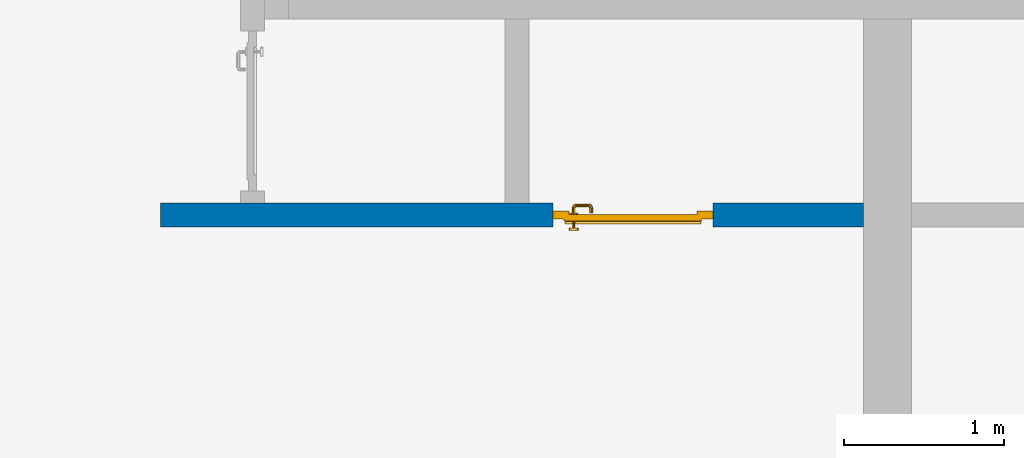
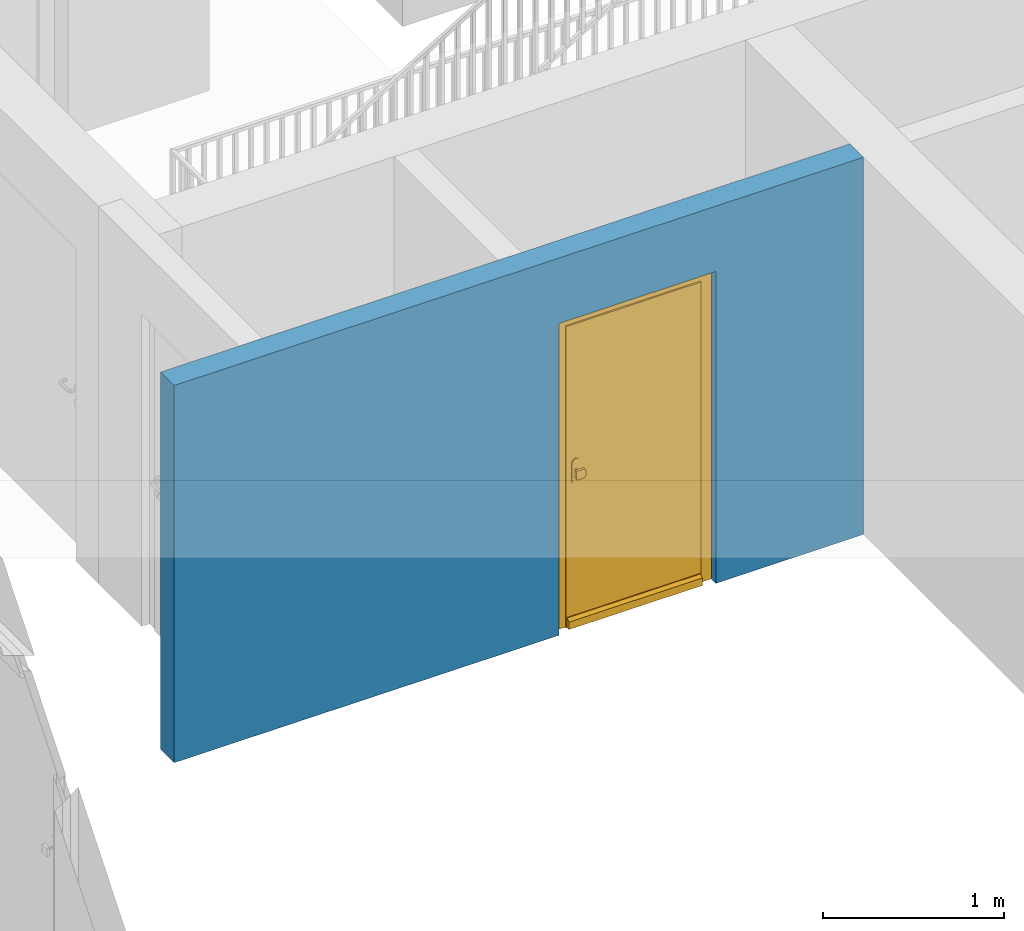
# One storey, part 2 of 54: 1 door, 1 wall, 1 opening.
"""IFC4 building model written with IfcOpenShell, lengths in metres."""

from ifc_helpers import new_model, entity, si_unit, converted_unit, derived_unit, direction, frame, origin_with_axes, place, context, subcontext, project, spatial, polygons, source, transform, mapped, material, type_object, element, fill, save


model = new_model("IFC4")

# Units and contexts
model_context = context("Model", 3, precision=1e-05, world=origin_with_axes(), true_north=direction((0.0, 1.0)))
body_context = subcontext(model_context, "Body", "Model", "MODEL_VIEW")
ifc_project = project(units=[si_unit("LENGTHUNIT", "METRE"), si_unit("AREAUNIT", "SQUARE_METRE"), si_unit("VOLUMEUNIT", "CUBIC_METRE"), converted_unit("PLANEANGLEUNIT", "DEGREE", entity("IfcPlaneAngleMeasure", 0.0174532925199), si_unit("PLANEANGLEUNIT", "RADIAN"), dimensions=[0, 0, 0, 0, 0, 0, 0]), converted_unit("TIMEUNIT", "Year", entity("IfcTimeMeasure", 31556926.0), si_unit("TIMEUNIT", "SECOND"), dimensions=[0, 0, 1, 0, 0, 0, 0]), si_unit("MASSUNIT", "GRAM", prefix="KILO"), si_unit("THERMODYNAMICTEMPERATUREUNIT", "DEGREE_CELSIUS"), si_unit("LUMINOUSINTENSITYUNIT", "LUMEN"), si_unit("ENERGYUNIT", "JOULE", prefix="MEGA"), derived_unit("THERMALCONDUCTANCEUNIT", [(si_unit("POWERUNIT", "WATT"), 1), (si_unit("LENGTHUNIT", "METRE"), -1), (si_unit("THERMODYNAMICTEMPERATUREUNIT", "KELVIN"), -1)]), derived_unit("SPECIFICHEATCAPACITYUNIT", [(si_unit("ENERGYUNIT", "JOULE"), 1), (si_unit("MASSUNIT", "GRAM", prefix="KILO"), -1), (si_unit("THERMODYNAMICTEMPERATUREUNIT", "KELVIN"), -1)]), derived_unit("MASSDENSITYUNIT", [(si_unit("MASSUNIT", "GRAM", prefix="KILO"), 1), (si_unit("VOLUMEUNIT", "CUBIC_METRE"), -1)])], contexts=[model_context])

# Site, building, storey
site_placement = place(None, origin_with_axes())
site = spatial("IfcSite", under=ifc_project, at=site_placement, CompositionType="ELEMENT")
building_placement = place(site_placement, origin_with_axes())
building = spatial("IfcBuilding", under=site, at=building_placement, CompositionType="ELEMENT")
storey_placement = place(building_placement, frame((0.0, 0.0, 6.29), z_axis=(0.0, 0.0, 1.0), x_axis=(1.0, 0.0, 0.0)))
storey = spatial("IfcBuildingStorey", under=building, at=storey_placement, Name="2. Geschoss", CompositionType="ELEMENT", Elevation=6.29)

# Wall, opening, door
ifc_material = material()
wall_type = type_object("IfcWallType", Name="150", PredefinedType="NOTDEFINED")
wall_placement = place(storey_placement, frame((-5.7421993804, -4.12881223104, 0.0), z_axis=(0.0, 0.0, 1.0), x_axis=(1.0, 0.0, 0.0)))
wall = element("IfcWall", 1, at=wall_placement, inside=storey, type_object=wall_type, material=ifc_material, Name="Wand-002", PredefinedType="NOTDEFINED", context=body_context, shape_type="Tessellation", body=[
    polygons([(2.45, 0.15, 2.1), (2.45, 0.15, 0.0), (0.0, 0.15, 0.0), (0.0, 0.15, 2.54), (4.39, 0.15, 2.54), (4.39, 0.15, 0.0), (3.45, 0.15, 0.0), (3.45, 0.15, 2.1), (2.45, 0.05, 0.0), (2.45, 0.0, 2.1), (2.45, 0.0, 0.0), (0.0, 0.0, 0.0), (0.0, 0.0, 2.54), (4.39, 0.0, 2.54), (4.39, 0.0, 0.0), (3.45, 0.05, 0.0), (3.45, 0.0, 0.0), (3.45, 0.0, 2.1)], [[[1, 2, 3, 4, 5, 6, 7, 8]], [[9, 2, 1, 10, 11]], [[2, 9, 11, 12, 3]], [[4, 3, 12, 13]], [[5, 4, 13, 14]], [[14, 15, 6, 5]], [[16, 7, 6, 15, 17]], [[8, 7, 16, 17, 18]], [[1, 8, 18, 10]], [[12, 11, 10, 18, 17, 15, 14, 13]]], closed=True),
])
opening_placement = place(wall_placement, frame((2.95, 0.0, 0.0), z_axis=(0.0, 0.0, 1.0), x_axis=(1.0, 0.0, 0.0)))
opening = element("IfcOpeningElement", 2, at=opening_placement, cuts=wall, context=body_context, identifier="Reference", shape_type="Tessellation", body=[
    polygons([(0.5, 0.05, 0.0), (0.5, 0.05, 2.1), (0.5, -0.001, 2.1), (0.5, -0.001, 0.0), (0.5, 0.151, 0.0), (0.5, 0.151, 2.1), (-0.5, 0.05, 2.1), (-0.5, -0.001, 2.1), (-0.5, 0.151, 2.1), (-0.5, -0.001, 0.0), (-0.5, 0.05, 0.0), (-0.5, 0.151, 0.0)], [[[1, 2, 3, 4]], [[2, 1, 5, 6]], [[7, 8, 3, 2, 6, 9]], [[8, 10, 4, 3]], [[1, 4, 10, 11, 12, 5]], [[6, 5, 12, 9]], [[7, 11, 10, 8]], [[11, 7, 9, 12]]], closed=True),
])
door_type = type_object("IfcDoorType", Name="Eingang 01 1-Fl 26", OperationType="SINGLE_SWING_LEFT", PredefinedType="DOOR")
shared_shape = source(origin_with_axes(), body_context, "Body", "Tessellation", [
    polygons([(-0.5, -0.05, 0.0), (-0.5, -0.05, 2.1), (-0.5, -0.03, 2.1), (-0.5, -0.03, 0.0), (-0.4, -0.05, 0.0), (-0.4, -0.05, 2.0), (-0.1301, -0.05, 2.0), (-0.0001, -0.05, 2.0), (0.4, -0.05, 2.0), (0.4, -0.05, 0.0), (0.5, -0.05, 0.0), (0.5, -0.05, 2.1), (0.5, -0.03, 2.1), (0.5, -0.03, 0.0), (0.4, -0.03, 0.0), (0.4, -0.03, 2.0), (-0.0001, -0.03, 2.0), (-0.1301, -0.03, 2.0), (-0.4, -0.03, 2.0), (-0.4, -0.03, 0.0)], [[[1, 2, 3, 4]], [[1, 5, 6, 7, 8, 9, 10, 11, 12, 2]], [[2, 12, 13, 3]], [[4, 3, 13, 14, 15, 16, 17, 18, 19, 20]], [[5, 1, 4, 20]], [[6, 5, 20, 19]], [[7, 6, 19, 18]], [[8, 7, 18, 17]], [[9, 8, 17, 16]], [[10, 9, 16, 15]], [[11, 10, 15, 14]], [[12, 11, 14, 13]]], closed=True),
    polygons([(-0.5, -0.03, 0.0), (-0.5, -0.03, 2.1), (-0.5, 0.0, 2.1), (-0.5, 0.0, 0.0), (-0.43, -0.03, 0.0), (-0.43, -0.03, 2.03), (-0.1001, -0.03, 2.03), (-0.0301, -0.03, 2.03), (0.43, -0.03, 2.03), (0.43, -0.03, 0.0), (0.5, -0.03, 0.0), (0.5, -0.03, 2.1), (0.5, 0.0, 2.1), (0.5, 0.0, 0.0), (0.43, 0.0, 0.0), (0.43, 0.0, 2.03), (-0.0301, 0.0, 2.03), (-0.1001, 0.0, 2.03), (-0.43, 0.0, 2.03), (-0.43, 0.0, 0.0)], [[[1, 2, 3, 4]], [[1, 5, 6, 7, 8, 9, 10, 11, 12, 2]], [[2, 12, 13, 3]], [[4, 3, 13, 14, 15, 16, 17, 18, 19, 20]], [[5, 1, 4, 20]], [[6, 5, 20, 19]], [[7, 6, 19, 18]], [[8, 7, 18, 17]], [[9, 8, 17, 16]], [[10, 9, 16, 15]], [[11, 10, 15, 14]], [[12, 11, 14, 13]]], closed=True),
    polygons([(-0.43, 0.01, 0.0), (-0.43, 0.01, 2.03), (0.43, 0.01, 2.03), (0.43, 0.01, 0.0), (-0.43, -0.03, 0.0), (-0.43, -0.03, 2.03), (0.43, -0.03, 2.03), (0.43, -0.03, 0.0)], [[[1, 2, 3, 4]], [[1, 5, 6, 2]], [[2, 6, 7, 3]], [[3, 7, 8, 4]], [[4, 8, 5, 1]], [[8, 7, 6, 5]]], closed=True),
    polygons([(-0.425, 0.03, 0.0), (-0.425, 0.03, 0.05), (0.425, 0.03, 0.05), (0.425, 0.03, 0.0), (-0.425, 0.01, 0.0), (-0.425, 0.01, 0.07), (-0.425, 0.015, 0.07), (0.425, 0.015, 0.07), (0.425, 0.01, 0.07), (0.425, 0.01, 0.0)], [[[1, 2, 3, 4]], [[1, 5, 6, 7, 2]], [[2, 7, 8, 3]], [[4, 3, 8, 9, 10]], [[5, 1, 4, 10]], [[6, 5, 10, 9]], [[7, 6, 9, 8]]], closed=True),
    polygons([(0.3835, -0.04, 1.0733826859), (0.3835, -0.0399, 1.0733826859), (0.37, -0.0399, 1.077), (0.37, -0.04, 1.077), (0.393382685902, -0.04, 1.0635), (0.393382685902, -0.0399, 1.0635), (0.3835, -0.0301, 1.0733826859), (0.37, -0.0301, 1.077), (0.3565, -0.0399, 1.0733826859), (0.3565, -0.04, 1.0733826859), (0.346617314098, -0.04, 1.0635), (0.343, -0.04, 1.05), (0.346617314098, -0.04, 1.0365), (0.3565, -0.04, 1.0266173141), (0.37, -0.04, 1.023), (0.3835, -0.04, 1.0266173141), (0.393382685902, -0.04, 1.0365), (0.397, -0.04, 1.05), (0.397, -0.0399, 1.05), (0.393382685902, -0.0301, 1.0635), (0.3835, -0.03, 1.0733826859), (0.37, -0.03, 1.077), (0.3565, -0.0301, 1.0733826859), (0.346617314098, -0.0399, 1.0635), (0.343, -0.0399, 1.05), (0.346617314098, -0.0399, 1.0365), (0.3565, -0.0399, 1.0266173141), (0.37, -0.0399, 1.023), (0.3835, -0.0399, 1.0266173141), (0.393382685902, -0.0399, 1.0365), (0.397, -0.0301, 1.05), (0.393382685902, -0.03, 1.0635), (0.397, -0.03, 1.05), (0.393382685902, -0.03, 1.0365), (0.3835, -0.03, 1.0266173141), (0.37, -0.03, 1.023), (0.3565, -0.03, 1.0266173141), (0.346617314098, -0.03, 1.0365), (0.343, -0.03, 1.05), (0.346617314098, -0.03, 1.0635), (0.3565, -0.03, 1.0733826859), (0.346617314098, -0.0301, 1.0635), (0.343, -0.0301, 1.05), (0.346617314098, -0.0301, 1.0365), (0.3565, -0.0301, 1.0266173141), (0.37, -0.0301, 1.023), (0.3835, -0.0301, 1.0266173141), (0.393382685902, -0.0301, 1.0365)], [[[1, 2, 3, 4]], [[5, 6, 2, 1]], [[2, 7, 8, 3]], [[4, 3, 9, 10]], [[4, 10, 11, 12, 13, 14, 15, 16, 17, 18, 5, 1]], [[18, 19, 6, 5]], [[6, 20, 7, 2]], [[7, 21, 22, 8]], [[3, 8, 23, 9]], [[10, 9, 24, 11]], [[11, 24, 25, 12]], [[12, 25, 26, 13]], [[13, 26, 27, 14]], [[14, 27, 28, 15]], [[15, 28, 29, 16]], [[16, 29, 30, 17]], [[17, 30, 19, 18]], [[19, 31, 20, 6]], [[20, 32, 21, 7]], [[22, 21, 32, 33, 34, 35, 36, 37, 38, 39, 40, 41]], [[8, 22, 41, 23]], [[9, 23, 42, 24]], [[24, 42, 43, 25]], [[25, 43, 44, 26]], [[26, 44, 45, 27]], [[27, 45, 46, 28]], [[28, 46, 47, 29]], [[29, 47, 48, 30]], [[30, 48, 31, 19]], [[31, 33, 32, 20]], [[48, 34, 33, 31]], [[47, 35, 34, 48]], [[46, 36, 35, 47]], [[45, 37, 36, 46]], [[44, 38, 37, 45]], [[43, 39, 38, 44]], [[42, 40, 39, 43]], [[23, 41, 40, 42]]], closed=True),
    polygons([(0.362532169224, -0.04, 0.959692280177), (0.363279754556, -0.04, 0.961639806549), (0.35655, -0.04, 0.973296083362), (0.346703916638, -0.04, 0.96345), (0.365, -0.04, 0.952886751346), (0.365, -0.04, 0.9544), (0.362532169224, -0.039, 0.959692280177), (0.363279754556, -0.039, 0.961639806549), (0.364624817685, -0.039, 0.965143815798), (0.364624817685, -0.04, 0.965143815798), (0.37, -0.04, 0.967425445323), (0.37, -0.04, 0.9769), (0.346617314098, -0.04, 0.9635), (0.3565, -0.04, 0.973382685902), (0.365, -0.04, 0.95), (0.3431, -0.04, 0.95), (0.365, -0.04, 0.947113248654), (0.365, -0.04, 0.941339745962), (0.365, -0.04, 0.9375), (0.365, -0.039, 0.9375), (0.365, -0.039, 0.941339745962), (0.365, -0.039, 0.947113248654), (0.365, -0.039, 0.95), (0.365, -0.039, 0.952886751346), (0.365, -0.039, 0.9544), (0.347569942042, -0.039, 0.96295), (0.35705, -0.039, 0.972430057958), (0.37, -0.039, 0.9759), (0.37, -0.039, 0.967425445323), (0.375375182315, -0.04, 0.965143815798), (0.376720245444, -0.04, 0.961639806549), (0.38345, -0.04, 0.973296083362), (0.37, -0.04, 0.977), (0.343, -0.04, 0.95), (0.346617314098, -0.0399, 0.9635), (0.3565, -0.0399, 0.973382685902), (0.346703916638, -0.04, 0.93655), (0.35655, -0.04, 0.926703916638), (0.37, -0.04, 0.9231), (0.37, -0.04, 0.9325), (0.366464466094, -0.04, 0.933964466094), (0.366464466094, -0.039, 0.933964466094), (0.37, -0.039, 0.9241), (0.35705, -0.039, 0.927569942042), (0.37, -0.039, 0.9325), (0.347569942042, -0.039, 0.93705), (0.3441, -0.039, 0.95), (0.347483339502, -0.039, 0.963), (0.357, -0.039, 0.972516660498), (0.37, -0.039, 0.976), (0.375375182315, -0.039, 0.965143815798), (0.38295, -0.039, 0.972430057958), (0.376720245444, -0.039, 0.961639806549), (0.377467830776, -0.039, 0.959692280177), (0.377467830776, -0.04, 0.959692280177), (0.375, -0.04, 0.9544), (0.375, -0.04, 0.952886751346), (0.393296083362, -0.04, 0.96345), (0.3835, -0.04, 0.973382685902), (0.37, -0.0399, 0.977), (0.346617314098, -0.04, 0.9365), (0.343, -0.0399, 0.95), (0.346617314098, -0.0301, 0.9635), (0.3565, -0.0301, 0.973382685902), (0.3565, -0.04, 0.926617314098), (0.37, -0.04, 0.923), (0.38345, -0.04, 0.926703916638), (0.375, -0.04, 0.941339745962), (0.375, -0.04, 0.9375), (0.373535533906, -0.04, 0.933964466094), (0.37, -0.039, 0.924), (0.357, -0.039, 0.927483339502), (0.38295, -0.039, 0.927569942042), (0.373535533906, -0.039, 0.933964466094), (0.375, -0.039, 0.9375), (0.375, -0.039, 0.941339745962), (0.347483339502, -0.039, 0.937), (0.344, -0.039, 0.95), (0.347483339502, -0.0389, 0.963), (0.357, -0.0389, 0.972516660498), (0.37, -0.0389, 0.976), (0.383, -0.039, 0.972516660498), (0.392430057958, -0.039, 0.96295), (0.375, -0.039, 0.952886751346), (0.375, -0.039, 0.9544), (0.375, -0.039, 0.95), (0.375, -0.039, 0.947113248654), (0.375, -0.04, 0.947113248654), (0.375, -0.04, 0.95), (0.3969, -0.04, 0.95), (0.393382685902, -0.04, 0.9635), (0.3835, -0.0399, 0.973382685902), (0.37, -0.0301, 0.977), (0.346617314098, -0.0399, 0.9365), (0.343, -0.0301, 0.95), (0.346617314098, -0.03, 0.9635), (0.3565, -0.03, 0.973382685902), (0.3565, -0.0399, 0.926617314098), (0.3835, -0.04, 0.926617314098), (0.37, -0.0399, 0.923), (0.393296083362, -0.04, 0.93655), (0.383, -0.039, 0.927483339502), (0.37, -0.0389, 0.924), (0.357, -0.0389, 0.927483339502), (0.392430057958, -0.039, 0.93705), (0.347483339502, -0.0389, 0.937), (0.344, -0.0389, 0.95), (0.347483339502, -0.0301, 0.963), (0.357, -0.0301, 0.972516660498), (0.37, -0.0301, 0.976), (0.383, -0.0389, 0.972516660498), (0.392516660498, -0.039, 0.963), (0.3959, -0.039, 0.95), (0.397, -0.04, 0.95), (0.393382685902, -0.0399, 0.9635), (0.3835, -0.0301, 0.973382685902), (0.37, -0.03, 0.977), (0.346617314098, -0.0301, 0.9365), (0.343, -0.03, 0.95), (0.346703916638, -0.03, 0.96345), (0.35655, -0.03, 0.973296083362), (0.3565, -0.0301, 0.926617314098), (0.393382685902, -0.04, 0.9365), (0.3835, -0.0399, 0.926617314098), (0.37, -0.0301, 0.923), (0.392516660498, -0.039, 0.937), (0.383, -0.0389, 0.927483339502), (0.37, -0.0301, 0.924), (0.357, -0.0301, 0.927483339502), (0.347483339502, -0.0301, 0.937), (0.344, -0.0301, 0.95), (0.347483339502, -0.03, 0.963), (0.357, -0.03, 0.972516660498), (0.37, -0.03, 0.976), (0.383, -0.0301, 0.972516660498), (0.392516660498, -0.0389, 0.963), (0.396, -0.039, 0.95), (0.397, -0.0399, 0.95), (0.393382685902, -0.0301, 0.9635), (0.3835, -0.03, 0.973382685902), (0.37, -0.03, 0.9769), (0.346617314098, -0.03, 0.9365), (0.3431, -0.03, 0.95), (0.347396736961, -0.03, 0.96305), (0.35695, -0.03, 0.972603263039), (0.3565, -0.03, 0.926617314098), (0.393382685902, -0.0399, 0.9365), (0.3835, -0.0301, 0.926617314098), (0.37, -0.03, 0.923), (0.392516660498, -0.0389, 0.937), (0.383, -0.0301, 0.927483339502), (0.37, -0.03, 0.924), (0.357, -0.03, 0.927483339502), (0.347483339502, -0.03, 0.937), (0.344, -0.03, 0.95), (0.37, -0.03, 0.9761), (0.383, -0.03, 0.972516660498), (0.392516660498, -0.0301, 0.963), (0.396, -0.0389, 0.95), (0.397, -0.0301, 0.95), (0.393382685902, -0.03, 0.9635), (0.38345, -0.03, 0.973296083362), (0.346703916638, -0.03, 0.93655), (0.3439, -0.03, 0.95), (0.35655, -0.03, 0.926703916638), (0.393382685902, -0.0301, 0.9365), (0.3835, -0.03, 0.926617314098), (0.37, -0.03, 0.9231), (0.392516660498, -0.0301, 0.937), (0.383, -0.03, 0.927483339502), (0.37, -0.03, 0.9239), (0.35695, -0.03, 0.927396736961), (0.347396736961, -0.03, 0.93695), (0.38305, -0.03, 0.972603263039), (0.392516660498, -0.03, 0.963), (0.396, -0.0301, 0.95), (0.397, -0.03, 0.95), (0.393296083362, -0.03, 0.96345), (0.393382685902, -0.03, 0.9365), (0.38345, -0.03, 0.926703916638), (0.392516660498, -0.03, 0.937), (0.38305, -0.03, 0.927396736961), (0.392603263039, -0.03, 0.96305), (0.396, -0.03, 0.95), (0.3969, -0.03, 0.95), (0.393296083362, -0.03, 0.93655), (0.392603263039, -0.03, 0.93695), (0.3961, -0.03, 0.95)], [[[1, 2, 3, 4, 5, 6]], [[1, 7, 8, 9, 10, 2]], [[10, 11, 12, 3, 2]], [[13, 4, 3, 14]], [[15, 5, 4, 16]], [[6, 5, 15, 17, 18, 19, 20, 21, 22, 23, 24, 25]], [[6, 25, 7, 1]], [[7, 25, 24, 26, 27, 8]], [[9, 8, 27, 28, 29]], [[10, 9, 29, 11]], [[30, 31, 32, 12, 11]], [[14, 3, 12, 33]], [[34, 16, 4, 13]], [[35, 13, 14, 36]], [[17, 15, 16, 37]], [[18, 17, 37, 38]], [[38, 39, 40, 41, 19, 18]], [[19, 41, 42, 20]], [[43, 44, 21, 20, 42, 45]], [[22, 21, 44, 46]], [[23, 22, 46, 47]], [[24, 23, 47, 26]], [[26, 48, 49, 27]], [[27, 49, 50, 28]], [[51, 29, 28, 52, 53]], [[11, 29, 51, 30]], [[30, 51, 53, 54, 55, 31]], [[55, 56, 57, 58, 32, 31]], [[33, 12, 32, 59]], [[36, 14, 33, 60]], [[61, 37, 16, 34]], [[62, 34, 13, 35]], [[63, 35, 36, 64]], [[65, 38, 37, 61]], [[66, 39, 38, 65]], [[39, 67, 68, 69, 70, 40]], [[41, 40, 45, 42]], [[43, 71, 72, 44]], [[73, 43, 45, 74, 75, 76]], [[44, 72, 77, 46]], [[46, 77, 78, 47]], [[47, 78, 48, 26]], [[48, 79, 80, 49]], [[49, 80, 81, 50]], [[28, 50, 82, 52]], [[54, 53, 52, 83, 84, 85]], [[55, 54, 85, 56]], [[85, 84, 86, 87, 76, 75, 69, 68, 88, 89, 57, 56]], [[57, 89, 90, 58]], [[59, 32, 58, 91]], [[60, 33, 59, 92]], [[64, 36, 60, 93]], [[94, 61, 34, 62]], [[95, 62, 35, 63]], [[96, 63, 64, 97]], [[98, 65, 61, 94]], [[99, 67, 39, 66]], [[100, 66, 65, 98]], [[88, 68, 67, 101]], [[70, 69, 75, 74]], [[40, 70, 74, 45]], [[73, 102, 71, 43]], [[71, 103, 104, 72]], [[76, 87, 105, 73]], [[72, 104, 106, 77]], [[77, 106, 107, 78]], [[78, 107, 79, 48]], [[79, 108, 109, 80]], [[80, 109, 110, 81]], [[50, 81, 111, 82]], [[52, 82, 112, 83]], [[86, 84, 83, 113]], [[87, 86, 113, 105]], [[89, 88, 101, 90]], [[91, 58, 90, 114]], [[92, 59, 91, 115]], [[93, 60, 92, 116]], [[97, 64, 93, 117]], [[118, 94, 62, 95]], [[119, 95, 63, 96]], [[120, 96, 97, 121]], [[122, 98, 94, 118]], [[123, 101, 67, 99]], [[124, 99, 66, 100]], [[125, 100, 98, 122]], [[105, 126, 102, 73]], [[102, 127, 103, 71]], [[103, 128, 129, 104]], [[104, 129, 130, 106]], [[106, 130, 131, 107]], [[107, 131, 108, 79]], [[108, 132, 133, 109]], [[109, 133, 134, 110]], [[81, 110, 135, 111]], [[82, 111, 136, 112]], [[83, 112, 137, 113]], [[113, 137, 126, 105]], [[114, 90, 101, 123]], [[115, 91, 114, 138]], [[116, 92, 115, 139]], [[117, 93, 116, 140]], [[121, 97, 117, 141]], [[142, 118, 95, 119]], [[143, 119, 96, 120]], [[144, 120, 121, 145]], [[146, 122, 118, 142]], [[147, 123, 99, 124]], [[148, 124, 100, 125]], [[149, 125, 122, 146]], [[126, 150, 127, 102]], [[127, 151, 128, 103]], [[128, 152, 153, 129]], [[129, 153, 154, 130]], [[130, 154, 155, 131]], [[131, 155, 132, 108]], [[132, 144, 145, 133]], [[133, 145, 156, 134]], [[110, 134, 157, 135]], [[111, 135, 158, 136]], [[112, 136, 159, 137]], [[137, 159, 150, 126]], [[138, 114, 123, 147]], [[139, 115, 138, 160]], [[140, 116, 139, 161]], [[141, 117, 140, 162]], [[145, 121, 141, 156]], [[163, 142, 119, 143]], [[164, 143, 120, 144]], [[165, 146, 142, 163]], [[166, 147, 124, 148]], [[167, 148, 125, 149]], [[168, 149, 146, 165]], [[150, 169, 151, 127]], [[151, 170, 152, 128]], [[152, 171, 172, 153]], [[153, 172, 173, 154]], [[154, 173, 164, 155]], [[155, 164, 144, 132]], [[134, 156, 174, 157]], [[135, 157, 175, 158]], [[136, 158, 176, 159]], [[159, 176, 169, 150]], [[160, 138, 147, 166]], [[161, 139, 160, 177]], [[162, 140, 161, 178]], [[156, 141, 162, 174]], [[173, 163, 143, 164]], [[172, 165, 163, 173]], [[179, 166, 148, 167]], [[180, 167, 149, 168]], [[171, 168, 165, 172]], [[169, 181, 170, 151]], [[170, 182, 171, 152]], [[157, 174, 183, 175]], [[158, 175, 184, 176]], [[176, 184, 181, 169]], [[177, 160, 166, 179]], [[178, 161, 177, 185]], [[174, 162, 178, 183]], [[186, 179, 167, 180]], [[182, 180, 168, 171]], [[181, 187, 182, 170]], [[175, 183, 188, 184]], [[184, 188, 187, 181]], [[185, 177, 179, 186]], [[183, 178, 185, 188]], [[187, 186, 180, 182]], [[188, 185, 186, 187]]], closed=True),
    polygons([(0.38, -0.04, 1.05), (0.38, -0.0709849140336, 1.05), (0.377071067812, -0.070696439392, 1.04292893219), (0.377071067812, -0.04, 1.04292893219), (0.377071067812, -0.04, 1.05707106781), (0.377071067812, -0.070696439392, 1.05707106781), (0.378277987014, -0.0796420579258, 1.05), (0.375518993221, -0.0784992452783, 1.04292893219), (0.37, -0.07, 1.04), (0.37, -0.04, 1.04), (0.37, -0.04, 1.06), (0.37, -0.07, 1.06), (0.375518993221, -0.0784992452783, 1.05707106781), (0.372816199938, -0.0878161999379, 1.05), (0.370704557509, -0.0857045575088, 1.04292893219), (0.368858192988, -0.0757402514855, 1.04), (0.362928932188, -0.069303560608, 1.04292893219), (0.362928932188, -0.04, 1.04292893219), (0.362928932188, -0.04, 1.05707106781), (0.362928932188, -0.069303560608, 1.05707106781), (0.368858192988, -0.0757402514855, 1.06), (0.370704557509, -0.0857045575088, 1.05707106781), (0.364642057926, -0.0932779870137, 1.05), (0.363499245278, -0.0905189932208, 1.04292893219), (0.365606601718, -0.0806066017178, 1.04), (0.362197392755, -0.0729812576926, 1.04292893219), (0.36, -0.0690150859664, 1.05), (0.36, -0.04, 1.05), (0.362197392755, -0.0729812576926, 1.05707106781), (0.365606601718, -0.0806066017178, 1.06), (0.363499245278, -0.0905189932208, 1.05707106781), (0.355984914034, -0.095, 1.05), (0.355696439392, -0.0920710678119, 1.04292893219), (0.360740251485, -0.0838581929877, 1.04), (0.360508645927, -0.0755086459268, 1.04292893219), (0.359438398962, -0.0718384450452, 1.05), (0.360508645927, -0.0755086459268, 1.05707106781), (0.360740251485, -0.0838581929877, 1.06), (0.355696439392, -0.0920710678119, 1.05707106781), (0.274015085966, -0.095, 1.05), (0.274303560608, -0.0920710678119, 1.04292893219), (0.355, -0.085, 1.04), (0.357981257693, -0.0771973927545, 1.04292893219), (0.358397003498, -0.0733970034977, 1.05), (0.357981257693, -0.0771973927545, 1.05707106781), (0.355, -0.085, 1.06), (0.274303560608, -0.0920710678119, 1.05707106781), (0.265357942074, -0.0932779870137, 1.05), (0.266500754722, -0.0905189932208, 1.04292893219), (0.275, -0.085, 1.04), (0.354303560608, -0.0779289321881, 1.04292893219), (0.356838445045, -0.0744383989617, 1.05), (0.354303560608, -0.0779289321881, 1.05707106781), (0.275, -0.085, 1.06), (0.266500754722, -0.0905189932208, 1.05707106781), (0.257183800062, -0.0878161999379, 1.05), (0.259295442491, -0.0857045575088, 1.04292893219), (0.269259748515, -0.0838581929877, 1.04), (0.275696439392, -0.0779289321881, 1.04292893219), (0.354015085966, -0.075, 1.05), (0.275696439392, -0.0779289321881, 1.05707106781), (0.269259748515, -0.0838581929877, 1.06), (0.259295442491, -0.0857045575088, 1.05707106781), (0.251722012986, -0.0796420579258, 1.05), (0.254481006779, -0.0784992452783, 1.04292893219), (0.264393398282, -0.0806066017178, 1.04), (0.272018742307, -0.0771973927545, 1.04292893219), (0.275984914034, -0.075, 1.05), (0.272018742307, -0.0771973927545, 1.05707106781), (0.264393398282, -0.0806066017178, 1.06), (0.254481006779, -0.0784992452783, 1.05707106781), (0.25, -0.0709849140336, 1.05), (0.252928932188, -0.070696439392, 1.04292893219), (0.261141807012, -0.0757402514855, 1.04), (0.269491354073, -0.0755086459268, 1.04292893219), (0.273161554955, -0.0744383989617, 1.05), (0.269491354073, -0.0755086459268, 1.05707106781), (0.261141807012, -0.0757402514855, 1.06), (0.252928932188, -0.070696439392, 1.05707106781), (0.25, -0.04, 1.05), (0.252928932188, -0.04, 1.04292893219), (0.26, -0.07, 1.04), (0.267802607245, -0.0729812576926, 1.04292893219), (0.271602996502, -0.0733970034977, 1.05), (0.267802607245, -0.0729812576926, 1.05707106781), (0.26, -0.07, 1.06), (0.252928932188, -0.04, 1.05707106781), (0.26, -0.04, 1.06), (0.267071067812, -0.04, 1.05707106781), (0.27, -0.04, 1.05), (0.267071067812, -0.04, 1.04292893219), (0.26, -0.04, 1.04), (0.267071067812, -0.069303560608, 1.04292893219), (0.270561601038, -0.0718384450452, 1.05), (0.267071067812, -0.069303560608, 1.05707106781), (0.27, -0.0690150859664, 1.05)], [[[1, 2, 3, 4]], [[5, 6, 2, 1]], [[2, 7, 8, 3]], [[4, 3, 9, 10]], [[11, 12, 6, 5]], [[6, 13, 7, 2]], [[7, 14, 15, 8]], [[3, 8, 16, 9]], [[10, 9, 17, 18]], [[19, 20, 12, 11]], [[12, 21, 13, 6]], [[13, 22, 14, 7]], [[14, 23, 24, 15]], [[8, 15, 25, 16]], [[9, 16, 26, 17]], [[18, 17, 27, 28]], [[28, 27, 20, 19]], [[20, 29, 21, 12]], [[21, 30, 22, 13]], [[22, 31, 23, 14]], [[23, 32, 33, 24]], [[15, 24, 34, 25]], [[16, 25, 35, 26]], [[17, 26, 36, 27]], [[27, 36, 29, 20]], [[29, 37, 30, 21]], [[30, 38, 31, 22]], [[31, 39, 32, 23]], [[32, 40, 41, 33]], [[24, 33, 42, 34]], [[25, 34, 43, 35]], [[26, 35, 44, 36]], [[36, 44, 37, 29]], [[37, 45, 38, 30]], [[38, 46, 39, 31]], [[39, 47, 40, 32]], [[40, 48, 49, 41]], [[33, 41, 50, 42]], [[34, 42, 51, 43]], [[35, 43, 52, 44]], [[44, 52, 45, 37]], [[45, 53, 46, 38]], [[46, 54, 47, 39]], [[47, 55, 48, 40]], [[48, 56, 57, 49]], [[41, 49, 58, 50]], [[42, 50, 59, 51]], [[43, 51, 60, 52]], [[52, 60, 53, 45]], [[53, 61, 54, 46]], [[54, 62, 55, 47]], [[55, 63, 56, 48]], [[56, 64, 65, 57]], [[49, 57, 66, 58]], [[50, 58, 67, 59]], [[51, 59, 68, 60]], [[60, 68, 61, 53]], [[61, 69, 62, 54]], [[62, 70, 63, 55]], [[63, 71, 64, 56]], [[64, 72, 73, 65]], [[57, 65, 74, 66]], [[58, 66, 75, 67]], [[59, 67, 76, 68]], [[68, 76, 69, 61]], [[69, 77, 70, 62]], [[70, 78, 71, 63]], [[71, 79, 72, 64]], [[72, 80, 81, 73]], [[65, 73, 82, 74]], [[66, 74, 83, 75]], [[67, 75, 84, 76]], [[76, 84, 77, 69]], [[77, 85, 78, 70]], [[78, 86, 79, 71]], [[79, 87, 80, 72]], [[80, 87, 88, 89, 90, 91, 92, 81]], [[73, 81, 92, 82]], [[74, 82, 93, 83]], [[75, 83, 94, 84]], [[84, 94, 85, 77]], [[85, 95, 86, 78]], [[86, 88, 87, 79]], [[95, 89, 88, 86]], [[96, 90, 89, 95]], [[93, 91, 90, 96]], [[82, 92, 91, 93]], [[83, 93, 96, 94]], [[94, 96, 95, 85]]], closed=False),
    polygons([(0.364696699141, 0.015, 1.04469669914), (0.37, 0.015, 1.0425), (0.375303300859, 0.015, 1.04469669914), (0.3775, 0.015, 1.05), (0.375303300859, 0.015, 1.05530330086), (0.37, 0.015, 1.0575), (0.364696699141, 0.015, 1.05530330086), (0.3625, 0.015, 1.05), (0.364696699141, 0.055, 1.04469669914), (0.37, 0.055, 1.0425), (0.375303300859, 0.055, 1.04469669914), (0.3775, 0.055, 1.05), (0.375303300859, 0.055, 1.05530330086), (0.37, 0.055, 1.0575), (0.364696699141, 0.055, 1.05530330086), (0.3625, 0.055, 1.05)], [[[1, 2, 3, 4, 5, 6, 7, 8]], [[2, 1, 9, 10]], [[3, 2, 10, 11]], [[4, 3, 11, 12]], [[5, 4, 12, 13]], [[6, 5, 13, 14]], [[7, 6, 14, 15]], [[8, 7, 15, 16]], [[1, 8, 16, 9]], [[9, 16, 15, 14, 13, 12, 11, 10]]], closed=True),
    polygons([(0.395, 0.01, 0.975), (0.393096988313, 0.01, 0.965432914191), (0.393096988313, 0.015, 0.965432914191), (0.395, 0.015, 0.975), (0.395, 0.01, 1.1), (0.393096988313, 0.01, 1.10956708581), (0.38767766953, 0.01, 1.11767766953), (0.379567085809, 0.01, 1.12309698831), (0.37, 0.01, 1.125), (0.360432914191, 0.01, 1.12309698831), (0.35232233047, 0.01, 1.11767766953), (0.346903011687, 0.01, 1.10956708581), (0.345, 0.01, 1.1), (0.345, 0.01, 0.975), (0.346903011687, 0.01, 0.965432914191), (0.35232233047, 0.01, 0.95732233047), (0.360432914191, 0.01, 0.951903011687), (0.37, 0.01, 0.95), (0.379567085809, 0.01, 0.951903011687), (0.38767766953, 0.01, 0.95732233047), (0.38767766953, 0.015, 0.95732233047), (0.379567085809, 0.015, 0.951903011687), (0.37, 0.015, 0.95), (0.360432914191, 0.015, 0.951903011687), (0.35232233047, 0.015, 0.95732233047), (0.346903011687, 0.015, 0.965432914191), (0.345, 0.015, 0.975), (0.345, 0.015, 1.1), (0.346903011687, 0.015, 1.10956708581), (0.35232233047, 0.015, 1.11767766953), (0.360432914191, 0.015, 1.12309698831), (0.37, 0.015, 1.125), (0.379567085809, 0.015, 1.12309698831), (0.38767766953, 0.015, 1.11767766953), (0.393096988313, 0.015, 1.10956708581), (0.395, 0.015, 1.1)], [[[1, 2, 3, 4]], [[1, 5, 6, 7, 8, 9, 10, 11, 12, 13, 14, 15, 16, 17, 18, 19, 20, 2]], [[2, 20, 21, 3]], [[4, 3, 21, 22, 23, 24, 25, 26, 27, 28, 29, 30, 31, 32, 33, 34, 35, 36]], [[5, 1, 4, 36]], [[6, 5, 36, 35]], [[7, 6, 35, 34]], [[8, 7, 34, 33]], [[9, 8, 33, 32]], [[10, 9, 32, 31]], [[11, 10, 31, 30]], [[12, 11, 30, 29]], [[13, 12, 29, 28]], [[14, 13, 28, 27]], [[15, 14, 27, 26]], [[16, 15, 26, 25]], [[17, 16, 25, 24]], [[18, 17, 24, 23]], [[19, 18, 23, 22]], [[20, 19, 22, 21]]], closed=True),
    polygons([(0.39, 0.055, 1.08), (0.395, 0.055, 1.07866025404), (0.395, 0.07, 1.07866025404), (0.39, 0.07, 1.08), (0.35, 0.055, 1.08), (0.345, 0.055, 1.07866025404), (0.341339745962, 0.055, 1.075), (0.34, 0.055, 1.07), (0.34, 0.055, 1.03), (0.341339745962, 0.055, 1.025), (0.345, 0.055, 1.02133974596), (0.35, 0.055, 1.02), (0.39, 0.055, 1.02), (0.395, 0.055, 1.02133974596), (0.398660254038, 0.055, 1.025), (0.4, 0.055, 1.03), (0.4, 0.055, 1.07), (0.398660254038, 0.055, 1.075), (0.398660254038, 0.07, 1.075), (0.4, 0.07, 1.07), (0.4, 0.07, 1.03), (0.398660254038, 0.07, 1.025), (0.395, 0.07, 1.02133974596), (0.39, 0.07, 1.02), (0.35, 0.07, 1.02), (0.345, 0.07, 1.02133974596), (0.341339745962, 0.07, 1.025), (0.34, 0.07, 1.03), (0.34, 0.07, 1.07), (0.341339745962, 0.07, 1.075), (0.345, 0.07, 1.07866025404), (0.35, 0.07, 1.08)], [[[1, 2, 3, 4]], [[1, 5, 6, 7, 8, 9, 10, 11, 12, 13, 14, 15, 16, 17, 18, 2]], [[2, 18, 19, 3]], [[4, 3, 19, 20, 21, 22, 23, 24, 25, 26, 27, 28, 29, 30, 31, 32]], [[5, 1, 4, 32]], [[6, 5, 32, 31]], [[7, 6, 31, 30]], [[8, 7, 30, 29]], [[9, 8, 29, 28]], [[10, 9, 28, 27]], [[11, 10, 27, 26]], [[12, 11, 26, 25]], [[13, 12, 25, 24]], [[14, 13, 24, 23]], [[15, 14, 23, 22]], [[16, 15, 22, 21]], [[17, 16, 21, 20]], [[18, 17, 20, 19]]], closed=True),
])
door_placement = place(opening_placement, frame((0.4, 0.0, 0.0), z_axis=(0.0, 0.0, 1.0), x_axis=(-1.0, 0.0, 0.0)))
door = element("IfcDoor", 3, at=door_placement, inside=storey, type_object=door_type, OverallHeight=2.1, OverallWidth=1.0, PredefinedType="DOOR", context=body_context, shape_type="MappedRepresentation", body=[
    mapped(shared_shape, transform((0.4, -0.05, 0.0))),
])
fill(opening, door)

save(model, "model.ifc")
